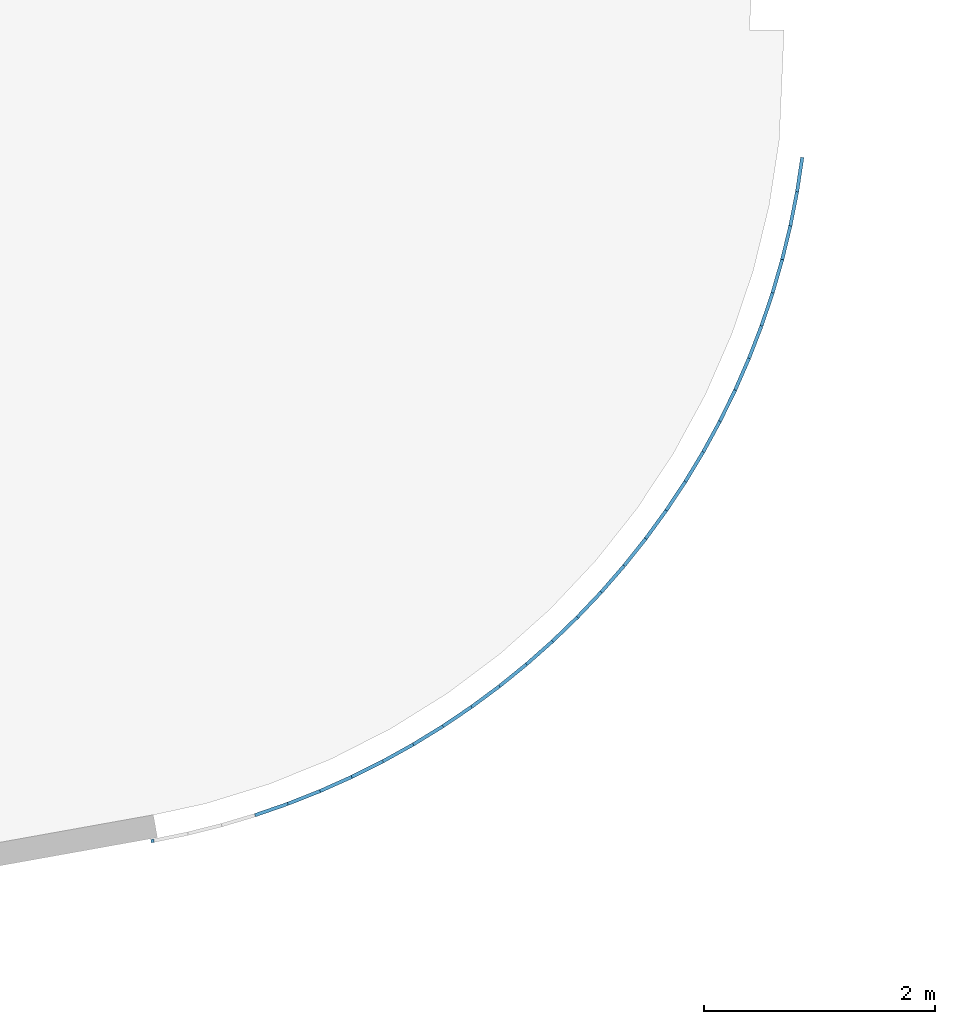
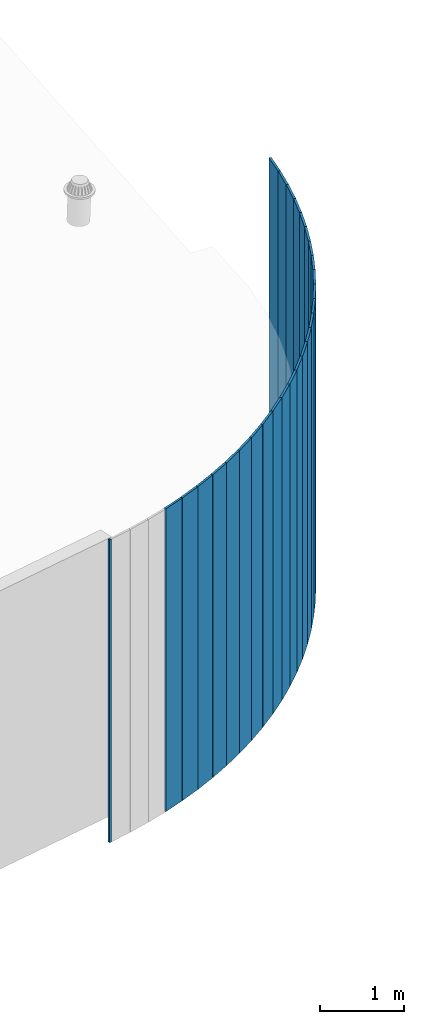
# One storey, part 7 of 18: 27 plates, 1 element without a shape of its own.
"""IFC2X3 building model written with IfcOpenShell, lengths in centimetres."""

from ifc_helpers import new_model, entity, si_unit, converted_unit, derived_unit, direction, frame, origin, origin_2d_with_axis, place, context, subcontext, project, spatial, rectangle, extrude, source, transform, mapped, material, layer, layer_set, layer_usage, type_object, type_shapes, element, aggregate, save


model = new_model("IFC2X3")

# Units and contexts
model_context = context("Model", 3, precision=0.001, world=origin(), true_north=direction((6.12303176911189e-17, 1.0)))
body_context = subcontext(model_context, "Body", "Model", "MODEL_VIEW")
ifc_project = project(units=[si_unit("LENGTHUNIT", "METRE", prefix="CENTI"), si_unit("AREAUNIT", "SQUARE_METRE"), si_unit("VOLUMEUNIT", "CUBIC_METRE"), converted_unit("PLANEANGLEUNIT", "DEGREE", entity("IfcRatioMeasure", 0.0174532925199433), si_unit("PLANEANGLEUNIT", "RADIAN"), dimensions=[0, 0, 0, 0, 0, 0, 0]), si_unit("MASSUNIT", "GRAM", prefix="KILO"), derived_unit("MASSDENSITYUNIT", [(si_unit("MASSUNIT", "GRAM", prefix="KILO"), 1), (si_unit("LENGTHUNIT", "METRE"), -3)]), si_unit("TIMEUNIT", "SECOND"), si_unit("FREQUENCYUNIT", "HERTZ"), si_unit("THERMODYNAMICTEMPERATUREUNIT", "DEGREE_CELSIUS"), derived_unit("THERMALTRANSMITTANCEUNIT", [(si_unit("MASSUNIT", "GRAM", prefix="KILO"), 1), (si_unit("THERMODYNAMICTEMPERATUREUNIT", "KELVIN"), -1), (si_unit("TIMEUNIT", "SECOND"), -3)]), derived_unit("VOLUMETRICFLOWRATEUNIT", [(si_unit("LENGTHUNIT", "METRE"), 3), (si_unit("TIMEUNIT", "SECOND"), -1)]), si_unit("ELECTRICCURRENTUNIT", "AMPERE"), si_unit("ELECTRICVOLTAGEUNIT", "VOLT"), si_unit("POWERUNIT", "WATT"), si_unit("FORCEUNIT", "NEWTON", prefix="KILO"), si_unit("ILLUMINANCEUNIT", "LUX"), si_unit("LUMINOUSFLUXUNIT", "LUMEN"), si_unit("LUMINOUSINTENSITYUNIT", "CANDELA"), derived_unit("USERDEFINED", [(si_unit("MASSUNIT", "GRAM", prefix="KILO"), -1), (si_unit("LENGTHUNIT", "METRE"), -2), (si_unit("TIMEUNIT", "SECOND"), 3), (si_unit("LUMINOUSFLUXUNIT", "LUMEN"), 1)]), derived_unit("LINEARVELOCITYUNIT", [(si_unit("LENGTHUNIT", "METRE"), 1), (si_unit("TIMEUNIT", "SECOND"), -1)]), si_unit("PRESSUREUNIT", "PASCAL"), derived_unit("USERDEFINED", [(si_unit("LENGTHUNIT", "METRE"), -2), (si_unit("MASSUNIT", "GRAM", prefix="KILO"), 1), (si_unit("TIMEUNIT", "SECOND"), -2)])], contexts=[model_context])

# Site, building, storey
site_placement = place(None, origin())
site = spatial("IfcSite", under=ifc_project, at=site_placement, CompositionType="ELEMENT")
building_placement = place(site_placement, origin())
building = spatial("IfcBuilding", under=site, at=building_placement, CompositionType="ELEMENT")
storey_placement = place(building_placement, frame((0.0, 0.0, 1422.0)))
storey = spatial("IfcBuildingStorey", under=building, at=storey_placement, CompositionType="ELEMENT", Elevation=1422.0)

# Curtain wall, plates
curtain_wall_type = type_object("IfcCurtainWallType", PredefinedType="NOTDEFINED")
curtain_wall_placement = place(storey_placement, frame((0.0, 0.0, -1422.0)))
curtain_wall = element("IfcCurtainWall", 1, at=curtain_wall_placement, inside=storey, type_object=curtain_wall_type)
ifc_material = material()
ifc_layer = layer(ifc_material, 3.0)
ifc_layer_set = layer_set([ifc_layer])
ifc_layer_usage_1 = layer_usage(ifc_layer_set, "AXIS3", "POSITIVE", 0.0492125984251968)
plate_type_1 = type_object("IfcPlateType", Name="Panneau plein ST", PredefinedType="CURTAIN_PANEL", material=ifc_layer_set)
shared_shape_1 = source(origin(), body_context, "Body", "SweptSolid", [
    extrude(rectangle(XDim=3.0, YDim=30.0000000000006, at=origin_2d_with_axis()), frame((0.0, 1.49999999999993, 0.0), z_axis=(0.0, 0.0, 1.0), x_axis=(0.0, 1.0, 0.0)), (0.0, 0.0, 1.0), 440.940384027565),
])
type_shapes(plate_type_1, [shared_shape_1])
plate_1_placement = place(curtain_wall_placement, frame((9909.33958888294, 880.775059713634, 981.059615973433), z_axis=(0.0, 0.0, 1.0), x_axis=(-0.149858560830442, -0.9887074449734, 0.0)))
plate_1 = element("IfcPlate", 2, at=plate_1_placement, type_object=plate_type_1, material=ifc_layer_usage_1, ObjectType="Panneau plein ST", context=body_context, shape_type="MappedRepresentation", body=[
    mapped(shared_shape_1, transform((0.0, 0.0, 0.0), scale=1.0)),
])
ifc_layer_usage_2 = layer_usage(ifc_layer_set, "AXIS3", "POSITIVE", 0.0492125984251968)
plate_2_placement = place(curtain_wall_placement, frame((9904.2012998867, 851.225564703089, 981.059615972435), z_axis=(0.0, 0.0, 1.0), x_axis=(-0.192694038919085, -0.981258889062948, 0.0)))
plate_2 = element("IfcPlate", 3, at=plate_2_placement, type_object=plate_type_1, material=ifc_layer_usage_2, ObjectType="Panneau plein ST", context=body_context, shape_type="MappedRepresentation", body=[
    mapped(shared_shape_1, transform((0.0, 0.0, 0.0), scale=1.0)),
])
ifc_layer_usage_3 = layer_usage(ifc_layer_set, "AXIS3", "POSITIVE", 0.0492125984251968)
plate_3_placement = place(curtain_wall_placement, frame((9897.78341046194, 821.927350345918, 981.059615972435), z_axis=(0.0, 0.0, 1.0), x_axis=(-0.235165256064731, -0.971955401415111, 0.0)))
plate_3 = element("IfcPlate", 4, at=plate_3_placement, type_object=plate_type_1, material=ifc_layer_usage_3, ObjectType="Panneau plein ST", context=body_context, shape_type="MappedRepresentation", body=[
    mapped(shared_shape_1, transform((0.0, 0.0, 0.0), scale=1.0)),
])
ifc_layer_usage_4 = layer_usage(ifc_layer_set, "AXIS3", "POSITIVE", 0.0492125984251968)
plate_4_placement = place(curtain_wall_placement, frame((9890.09805272478, 792.935800790244, 981.059615972435), z_axis=(0.0, 0.0, 1.0), x_axis=(-0.277191926412529, -0.960814568963081, 0.0)))
plate_4 = element("IfcPlate", 5, at=plate_4_placement, type_object=plate_type_1, material=ifc_layer_usage_4, ObjectType="Panneau plein ST", context=body_context, shape_type="MappedRepresentation", body=[
    mapped(shared_shape_1, transform((0.0, 0.0, 0.0), scale=1.0)),
])
ifc_layer_usage_5 = layer_usage(ifc_layer_set, "AXIS3", "POSITIVE", 0.0492125984251968)
plate_5_placement = place(curtain_wall_placement, frame((9881.15975476168, 764.305720477571, 981.059615972435), z_axis=(0.0, 0.0, 1.0), x_axis=(-0.318694604460766, -0.947857451881661, 0.0)))
plate_5 = element("IfcPlate", 6, at=plate_5_placement, type_object=plate_type_1, material=ifc_layer_usage_5, ObjectType="Panneau plein ST", context=body_context, shape_type="MappedRepresentation", body=[
    mapped(shared_shape_1, transform((0.0, 0.0, 0.0), scale=1.0)),
])
ifc_layer_usage_6 = layer_usage(ifc_layer_set, "AXIS3", "POSITIVE", 0.0492125984251968)
plate_6_placement = place(curtain_wall_placement, frame((9870.98541316615, 736.09123054271, 981.059615972435), z_axis=(0.0, 0.0, 1.0), x_axis=(-0.359594835241633, -0.93310854377588, 0.0)))
plate_6 = element("IfcPlate", 7, at=plate_6_placement, type_object=plate_type_1, material=ifc_layer_usage_6, ObjectType="Panneau plein ST", context=body_context, shape_type="MappedRepresentation", body=[
    mapped(shared_shape_1, transform((0.0, 0.0, 0.0), scale=1.0)),
])
ifc_layer_usage_7 = layer_usage(ifc_layer_set, "AXIS3", "POSITIVE", 0.0492125984251968)
plate_7_placement = place(curtain_wall_placement, frame((9859.59426109809, 708.34566650538, 981.059615972435), z_axis=(0.0, 0.0, 1.0), x_axis=(-0.399815302628858, -0.916595725379403, 0.0)))
plate_7 = element("IfcPlate", 8, at=plate_7_placement, type_object=plate_type_1, material=ifc_layer_usage_7, ObjectType="Panneau plein ST", context=body_context, shape_type="MappedRepresentation", body=[
    mapped(shared_shape_1, transform((0.0, 0.0, 0.0), scale=1.0)),
])
ifc_layer_usage_8 = layer_usage(ifc_layer_set, "AXIS3", "POSITIVE", 0.0492125984251968)
plate_8_placement = place(curtain_wall_placement, frame((9847.00783192626, 681.121477446941, 981.059615972435), z_axis=(0.0, 0.0, 1.0), x_axis=(-0.439279975493202, -0.898350211849862, 0.0)))
plate_8 = element("IfcPlate", 9, at=plate_8_placement, type_object=plate_type_1, material=ifc_layer_usage_8, ObjectType="Panneau plein ST", context=body_context, shape_type="MappedRepresentation", body=[
    mapped(shared_shape_1, transform((0.0, 0.0, 0.0), scale=1.0)),
])
ifc_layer_usage_9 = layer_usage(ifc_layer_set, "AXIS3", "POSITIVE", 0.0492125984251968)
plate_9_placement = place(curtain_wall_placement, frame((9833.24991852244, 654.470126862776, 981.059615972435), z_axis=(0.0, 0.0, 1.0), x_axis=(-0.477914251428343, -0.87840649376111, 0.0)))
plate_9 = element("IfcPlate", 10, at=plate_9_placement, type_object=plate_type_1, material=ifc_layer_usage_9, ObjectType="Panneau plein ST", context=body_context, shape_type="MappedRepresentation", body=[
    mapped(shared_shape_1, transform((0.0, 0.0, 0.0), scale=1.0)),
])
ifc_layer_usage_10 = layer_usage(ifc_layer_set, "AXIS3", "POSITIVE", 0.0492125984251968)
plate_10_placement = place(curtain_wall_placement, frame((9818.34652828436, 628.441995377809, 981.059615972435), z_axis=(0.0, 0.0, 1.0), x_axis=(-0.515645097776738, -0.856802271903395, 0.0)))
plate_10 = element("IfcPlate", 11, at=plate_10_placement, type_object=plate_type_1, material=ifc_layer_usage_10, ObjectType="Panneau plein ST", context=body_context, shape_type="MappedRepresentation", body=[
    mapped(shared_shape_1, transform((0.0, 0.0, 0.0), scale=1.0)),
])
ifc_layer_usage_11 = layer_usage(ifc_layer_set, "AXIS3", "POSITIVE", 0.0492125984251968)
plate_11_placement = place(curtain_wall_placement, frame((9802.3258339724, 603.086285509024, 981.059615972435), z_axis=(0.0, 0.0, 1.0), x_axis=(-0.552401189687027, -0.833578386015591, 0.0)))
plate_11 = element("IfcPlate", 12, at=plate_11_placement, type_object=plate_type_1, material=ifc_layer_usage_11, ObjectType="Panneau plein ST", context=body_context, shape_type="MappedRepresentation", body=[
    mapped(shared_shape_1, transform((0.0, 0.0, 0.0), scale=1.0)),
])
ifc_layer_usage_12 = layer_usage(ifc_layer_set, "AXIS3", "POSITIVE", 0.0492125984251968)
plate_12_placement = place(curtain_wall_placement, frame((9785.21812045294, 578.450928655038, 981.059615972435), z_axis=(0.0, 0.0, 1.0), x_axis=(-0.588113044943713, -0.808778737583423, 0.0)))
plate_12 = element("IfcPlate", 13, at=plate_12_placement, type_object=plate_type_1, material=ifc_layer_usage_12, ObjectType="Panneau plein ST", context=body_context, shape_type="MappedRepresentation", body=[
    mapped(shared_shape_1, transform((0.0, 0.0, 0.0), scale=1.0)),
])
ifc_layer_usage_13 = layer_usage(ifc_layer_set, "AXIS3", "POSITIVE", 0.0492125984251968)
plate_13_placement = place(curtain_wall_placement, frame((9767.05572744907, 554.582494488544, 981.059615972435), z_axis=(0.0, 0.0, 1.0), x_axis=(-0.622713155314065, -0.782450206849485, 0.0)))
plate_13 = element("IfcPlate", 14, at=plate_13_placement, type_object=plate_type_1, material=ifc_layer_usage_13, ObjectType="Panneau plein ST", context=body_context, shape_type="MappedRepresentation", body=[
    mapped(shared_shape_1, transform((0.0, 0.0, 0.0), scale=1.0)),
])
ifc_layer_usage_14 = layer_usage(ifc_layer_set, "AXIS3", "POSITIVE", 0.0492125984251968)
plate_14_placement = place(curtain_wall_placement, frame((9747.87298840693, 531.526102922902, 981.059615972435), z_axis=(0.0, 0.0, 1.0), x_axis=(-0.656136114162017, -0.754642564193386, 0.0)))
plate_14 = element("IfcPlate", 15, at=plate_14_placement, type_object=plate_type_1, material=ifc_layer_usage_14, ObjectType="Panneau plein ST", context=body_context, shape_type="MappedRepresentation", body=[
    mapped(shared_shape_1, transform((0.0, 0.0, 0.0), scale=1.0)),
])
ifc_layer_usage_15 = layer_usage(ifc_layer_set, "AXIS3", "POSITIVE", 0.0492125984251968)
plate_15_placement = place(curtain_wall_placement, frame((9727.70616559314, 509.325338819291, 981.059615972435), z_axis=(0.0, 0.0, 1.0), x_axis=(-0.688318740090934, -0.725408376047334, 0.0)))
plate_15 = element("IfcPlate", 16, at=plate_15_placement, type_object=plate_type_1, material=ifc_layer_usage_15, ObjectType="Panneau plein ST", context=body_context, shape_type="MappedRepresentation", body=[
    mapped(shared_shape_1, transform((0.0, 0.0, 0.0), scale=1.0)),
])
ifc_layer_usage_16 = layer_usage(ifc_layer_set, "AXIS3", "POSITIVE", 0.0492125984251968)
plate_16_placement = place(curtain_wall_placement, frame((9706.59338154609, 488.022169595678, 981.059615972435), z_axis=(0.0, 0.0, 1.0), x_axis=(-0.719200196378883, -0.694802905526867, 0.0)))
plate_16 = element("IfcPlate", 17, at=plate_16_placement, type_object=plate_type_1, material=ifc_layer_usage_16, ObjectType="Panneau plein ST", context=body_context, shape_type="MappedRepresentation", body=[
    mapped(shared_shape_1, transform((0.0, 0.0, 0.0), scale=1.0)),
])
ifc_layer_usage_17 = layer_usage(ifc_layer_set, "AXIS3", "POSITIVE", 0.0492125984251968)
plate_17_placement = place(curtain_wall_placement, frame((9684.57454701068, 467.656865893317, 981.059615972435), z_axis=(0.0, 0.0, 1.0), x_axis=(-0.748722105981784, -0.662884007963839, 0.0)))
plate_17 = element("IfcPlate", 18, at=plate_17_placement, type_object=plate_type_1, material=ifc_layer_usage_17, ObjectType="Panneau plein ST", context=body_context, shape_type="MappedRepresentation", body=[
    mapped(shared_shape_1, transform((0.0, 0.0, 0.0), scale=1.0)),
])
ifc_layer_usage_18 = layer_usage(ifc_layer_set, "AXIS3", "POSITIVE", 0.0492125984251968)
plate_18_placement = place(curtain_wall_placement, frame((9661.69128549265, 448.267925450776, 981.059615972435), z_axis=(0.0, 0.0, 1.0), x_axis=(-0.776828661887188, -0.629712021538863, 0.0)))
plate_18 = element("IfcPlate", 19, at=plate_18_placement, type_object=plate_type_1, material=ifc_layer_usage_18, ObjectType="Panneau plein ST", context=body_context, shape_type="MappedRepresentation", body=[
    mapped(shared_shape_1, transform((0.0, 0.0, 0.0), scale=1.0)),
])
ifc_layer_usage_19 = layer_usage(ifc_layer_set, "AXIS3", "POSITIVE", 0.0492125984251968)
plate_19_placement = place(curtain_wall_placement, frame((9637.98685457519, 429.892000329383, 981.059615972435), z_axis=(0.0, 0.0, 1.0), x_axis=(-0.803466732609437, -0.595349653220623, 0.0)))
plate_19 = element("IfcPlate", 20, at=plate_19_placement, type_object=plate_type_1, material=ifc_layer_usage_19, ObjectType="Panneau plein ST", context=body_context, shape_type="MappedRepresentation", body=[
    mapped(shared_shape_1, transform((0.0, 0.0, 0.0), scale=1.0)),
])
ifc_layer_usage_20 = layer_usage(ifc_layer_set, "AXIS3", "POSITIVE", 0.0492125984251968)
plate_20_placement = place(curtain_wall_placement, frame((9613.50606414664, 412.563827627668, 981.059615972435), z_axis=(0.0, 0.0, 1.0), x_axis=(-0.828585962627321, -0.559861860227106, 0.0)))
plate_20 = element("IfcPlate", 21, at=plate_20_placement, type_object=plate_type_1, material=ifc_layer_usage_20, ObjectType="Panneau plein ST", context=body_context, shape_type="MappedRepresentation", body=[
    mapped(shared_shape_1, transform((0.0, 0.0, 0.0), scale=1.0)),
])
ifc_layer_usage_21 = layer_usage(ifc_layer_set, "AXIS3", "POSITIVE", 0.0492125984251968)
plate_21_placement = place(curtain_wall_placement, frame((9588.29519169362, 396.316163815764, 981.059615972435), z_axis=(0.0, 0.0, 1.0), x_axis=(-0.852138867574075, -0.523315727233162, 0.0)))
plate_21 = element("IfcPlate", 22, at=plate_21_placement, type_object=plate_type_1, material=ifc_layer_usage_21, ObjectType="Panneau plein ST", context=body_context, shape_type="MappedRepresentation", body=[
    mapped(shared_shape_1, transform((0.0, 0.0, 0.0), scale=1.0)),
])
ifc_layer_usage_22 = layer_usage(ifc_layer_set, "AXIS3", "POSITIVE", 0.0492125984251968)
plate_22_placement = place(curtain_wall_placement, frame((9562.40189482001, 381.179722813921, 981.059615972435), z_axis=(0.0, 0.0, 1.0), x_axis=(-0.874080923999901, -0.485780339556346, 0.0)))
plate_22 = element("IfcPlate", 23, at=plate_22_placement, type_object=plate_type_1, material=ifc_layer_usage_22, ObjectType="Panneau plein ST", context=body_context, shape_type="MappedRepresentation", body=[
    mapped(shared_shape_1, transform((0.0, 0.0, 0.0), scale=1.0)),
])
ifc_layer_usage_23 = layer_usage(ifc_layer_set, "AXIS3", "POSITIVE", 0.0492125984251968)
plate_23_placement = place(curtain_wall_placement, frame((9535.87512115695, 367.183117932161, 981.059615972435), z_axis=(0.0, 0.0, 1.0), x_axis=(-0.894370653537248, -0.447326652560918, 0.0)))
plate_23 = element("IfcPlate", 24, at=plate_23_placement, type_object=plate_type_1, material=ifc_layer_usage_23, ObjectType="Panneau plein ST", context=body_context, shape_type="MappedRepresentation", body=[
    mapped(shared_shape_1, transform((0.0, 0.0, 0.0), scale=1.0)),
])
ifc_layer_usage_24 = layer_usage(ifc_layer_set, "AXIS3", "POSITIVE", 0.0492125984251968)
plate_24_placement = place(curtain_wall_placement, frame((9508.76501583425, 354.352807780849, 981.059615972435), z_axis=(0.0, 0.0, 1.0), x_axis=(-0.912969701309877, -0.408027357526617, 0.0)))
plate_24 = element("IfcPlate", 25, at=plate_24_placement, type_object=plate_type_1, material=ifc_layer_usage_24, ObjectType="Panneau plein ST", context=body_context, shape_type="MappedRepresentation", body=[
    mapped(shared_shape_1, transform((0.0, 0.0, 0.0), scale=1.0)),
])
ifc_layer_usage_25 = layer_usage(ifc_layer_set, "AXIS3", "POSITIVE", 0.0492125984251968)
plate_25_placement = place(curtain_wall_placement, frame((9481.12282668804, 342.713046254407, 981.059615972435), z_axis=(0.0, 0.0, 1.0), x_axis=(-0.929842908437319, -0.367956744236095, 0.0)))
plate_25 = element("IfcPlate", 26, at=plate_25_placement, type_object=plate_type_1, material=ifc_layer_usage_25, ObjectType="Panneau plein ST", context=body_context, shape_type="MappedRepresentation", body=[
    mapped(shared_shape_1, transform((0.0, 0.0, 0.0), scale=1.0)),
])
ifc_layer_usage_26 = layer_usage(ifc_layer_set, "AXIS3", "POSITIVE", 0.0492125984251968)
plate_26_placement = place(curtain_wall_placement, frame((9453.00080738401, 332.285836682756, 981.059615972435), z_axis=(0.0, 0.0, 1.0), x_axis=(-0.944958378497752, -0.327190560540641, 0.0)))
plate_26 = element("IfcPlate", 27, at=plate_26_placement, type_object=plate_type_1, material=ifc_layer_usage_26, ObjectType="Panneau plein ST", context=body_context, shape_type="MappedRepresentation", body=[
    mapped(shared_shape_1, transform((0.0, 0.0, 0.0), scale=1.0)),
])
ifc_layer_usage_27 = layer_usage(ifc_layer_set, "AXIS3", "POSITIVE", 0.0492125984251968)
plate_type_2 = type_object("IfcPlateType", Name="Panneau plein ST", PredefinedType="CURTAIN_PANEL", material=ifc_layer_set)
shared_shape_2 = source(origin(), body_context, "Body", "SweptSolid", [
    extrude(rectangle(XDim=3.0, YDim=2.63158339934512, at=origin_2d_with_axis()), frame((0.0, 1.50000000000011, 0.0), z_axis=(0.0, 0.0, 1.0), x_axis=(0.0, 1.0, 0.0)), (0.0, 0.0, 1.0), 440.940384027565),
])
type_shapes(plate_type_2, [shared_shape_2])
plate_27_placement = place(curtain_wall_placement, frame((9350.30425012033, 305.207951089244, 981.059615972435), z_axis=(0.0, 0.0, 1.0), x_axis=(-0.983980164815788, -0.178277971856018, 0.0)))
plate_27 = element("IfcPlate", 28, at=plate_27_placement, type_object=plate_type_2, material=ifc_layer_usage_27, ObjectType="Panneau plein ST", context=body_context, shape_type="MappedRepresentation", body=[
    mapped(shared_shape_2, transform((0.0, 0.0, 0.0), scale=1.0)),
])
aggregate(curtain_wall, [plate_1, plate_2, plate_3, plate_4, plate_5, plate_6, plate_7, plate_8, plate_9, plate_10, plate_11, plate_12, plate_13, plate_14, plate_15, plate_16, plate_17, plate_18, plate_19, plate_20, plate_21, plate_22, plate_23, plate_24, plate_25, plate_26, plate_27])

save(model, "model.ifc")
